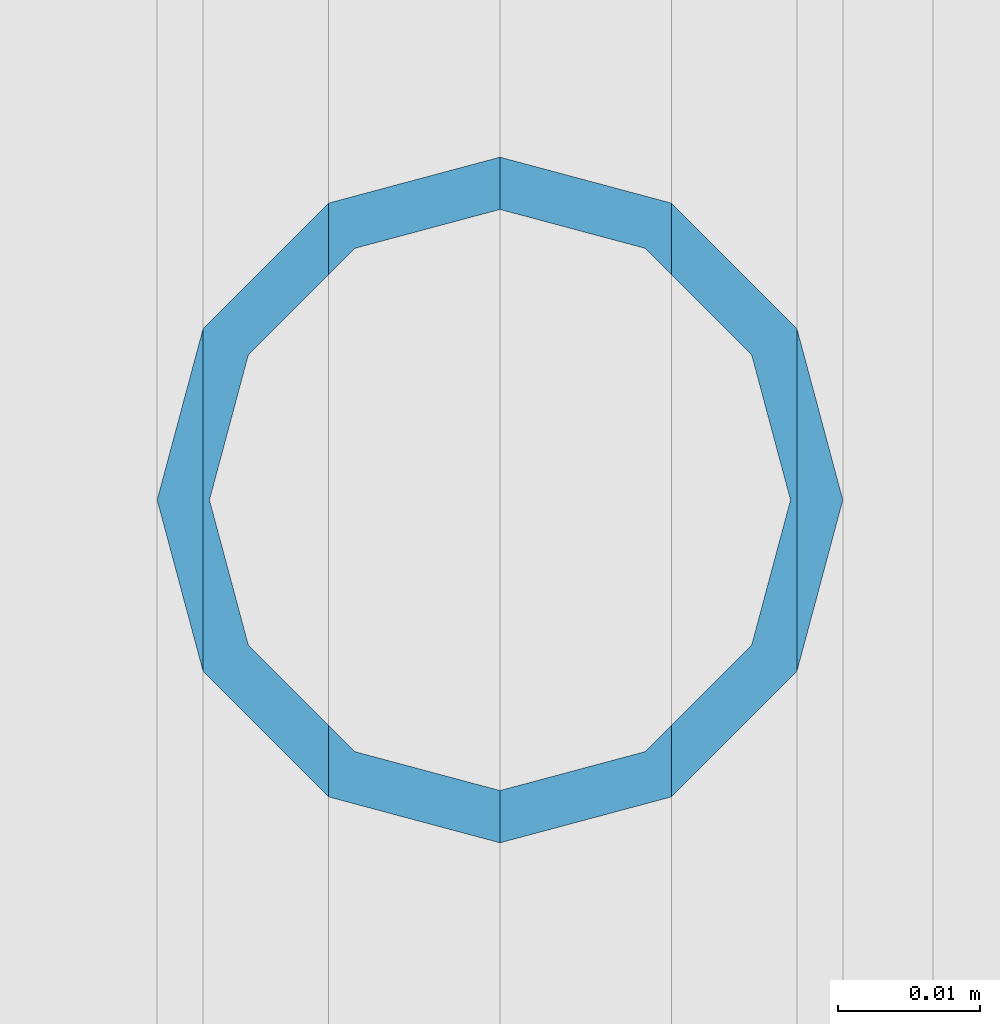
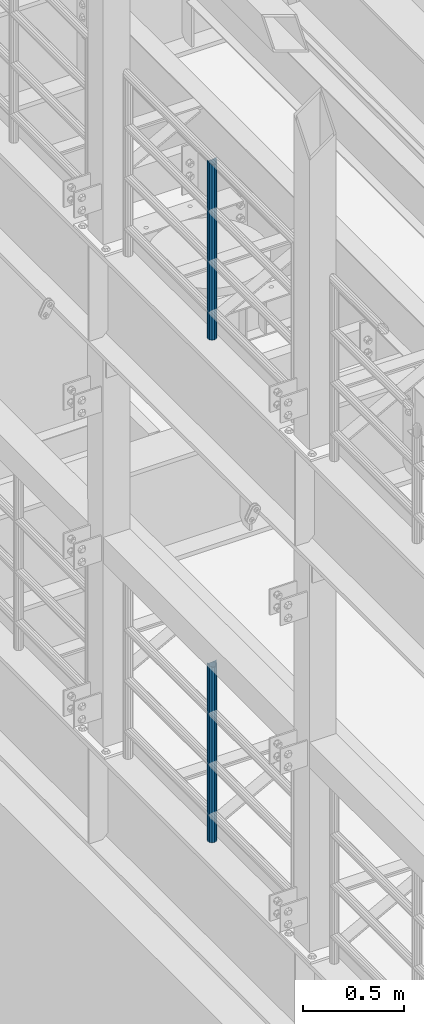
# One storey, part 677 of 1876: 2 columns, 2 elements without a shape of their own.
"""IFC2X3 building model written with IfcOpenShell, lengths in millimetres."""

from ifc_helpers import new_model, si_unit, frame, origin_with_axes, place, context, subcontext, project, spatial, faceted_brep, material, type_object, element, aggregate, save


model = new_model("IFC2X3")

# Units and contexts
model_context = context("Model", 3, precision=1e-05, world=origin_with_axes())
body_context = subcontext(model_context, "Body", "Model", "MODEL_VIEW")
ifc_project = project(units=[si_unit("LENGTHUNIT", "METRE", prefix="MILLI"), si_unit("AREAUNIT", "SQUARE_METRE"), si_unit("VOLUMEUNIT", "CUBIC_METRE"), si_unit("MASSUNIT", "GRAM", prefix="KILO"), si_unit("TIMEUNIT", "SECOND"), si_unit("PLANEANGLEUNIT", "RADIAN"), si_unit("SOLIDANGLEUNIT", "STERADIAN"), si_unit("THERMODYNAMICTEMPERATUREUNIT", "DEGREE_CELSIUS"), si_unit("LUMINOUSINTENSITYUNIT", "LUMEN")], contexts=[model_context])

# Site, building, storey
site_placement = place(None, origin_with_axes())
site = spatial("IfcSite", under=ifc_project, at=site_placement, CompositionType="ELEMENT")
building_placement = place(site_placement, origin_with_axes())
building = spatial("IfcBuilding", under=site, at=building_placement, Name="Undefined", CompositionType="ELEMENT")
storey_placement = place(building_placement, origin_with_axes())
storey = spatial("IfcBuildingStorey", under=building, at=storey_placement, Name="Undefined", CompositionType="ELEMENT", Elevation=0.0)

# Assembly, column
assembly_1_placement = place(storey_placement, origin_with_axes())
assembly_1 = element("IfcElementAssembly", 1, at=assembly_1_placement, inside=storey, Name="RAIL", AssemblyPlace="NOTDEFINED", PredefinedType="RIGID_FRAME")
ifc_material = material()
column_type = type_object("IfcColumnType", Name="PIPE1-1/2SCH40", PredefinedType="NOTDEFINED")
column_1_placement = place(assembly_1_placement, frame((-1.81898940354586e-12, -1524.0, 8153.4), z_axis=(0.0, 1.0, 0.0), x_axis=(0.0, 0.0, 1.0)))
column_1 = element("IfcColumn", 2, at=column_1_placement, type_object=column_type, material=ifc_material, Name="POST", ObjectType="PIPE1-1/2SCH40", context=body_context, shape_type="Brep", body=[
    faceted_brep([(1055.42780700668, -12.0650000000001, 20.8971929933186), (1055.42780700668, -12.0650000000001, 15.8661214311805), (1054.93437856882, -10.2235000000001, 17.7076214311801), (1052.195, 0.0, 20.4470000000001), (1052.195, 0.0, 24.1300000000001), (1054.93437856882, 10.2235000000001, 17.7076214311801), (1055.42780700668, 12.0650000000001, 15.8661214311805), (1055.42780700668, 12.0650000000001, 20.8971929933186), (1076.325, 24.1300000000001, 0.0), (1064.26, 20.8971929933184, 12.0649999999996), (1064.25999999999, 20.8971929933186, -12.0649999999996), (1061.07042843786, 17.7076214311803, 10.2235000000001), (1063.80980700668, 20.4469999999999, 0.0), (1061.07042843786, 17.7076214311803, -10.2235000000001), (1055.42780700668, 12.0650000000001, -15.8661214311805), (1055.42780700667, 12.0649999999996, -20.8971929933186), (1054.93437856882, 10.2235000000001, -17.7076214311801), (1052.195, 0.0, -20.4470000000001), (1052.19499999999, 0.0, -24.1300000000001), (1055.42780700668, -12.0650000000001, -15.8661214311805), (1055.42780700667, -12.0649999999996, -20.8971929933186), (1054.93437856882, -10.2235000000001, -17.7076214311801), (1076.325, -24.1300000000001, 0.0), (1064.25999999999, -20.8971929933186, -12.0649999999996), (1064.26, -20.8971929933184, 12.0649999999996), (1061.07042843786, -17.7076214311803, -10.2235000000001), (1063.80980700668, -20.4469999999999, 0.0), (1061.07042843786, -17.7076214311803, 10.2235000000001), (0.0, -20.8971929933184, -12.0649999999996), (0.0, -12.0650000000001, -20.8971929933186), (-1.45519152283669e-11, 0.0, -24.130000000001), (0.0, 12.0650000000001, -20.8971929933186), (0.0, 20.8971929933184, -12.0649999999996), (0.0, 24.1299999999992, 0.0), (0.0, 20.8971929933184, 12.0649999999996), (0.0, 12.0650000000001, 20.8971929933186), (-1.45519152283669e-11, 0.0, 24.130000000001), (0.0, -12.0650000000001, 20.8971929933186), (0.0, -20.8971929933184, 12.0649999999996), (0.0, -24.1299999999992, 0.0), (0.0, -17.7076214311803, -10.2235000000001), (0.0, -10.2235000000001, -17.7076214311801), (-1.45519152283669e-11, 0.0, -20.4470000000001), (0.0, 10.2235000000001, -17.7076214311801), (0.0, 17.7076214311803, -10.2235000000001), (0.0, 20.4469999999999, 0.0), (0.0, 17.7076214311803, 10.2235000000001), (0.0, 10.2235000000001, 17.7076214311801), (-1.45519152283669e-11, 0.0, 20.4470000000001), (0.0, -10.2235000000001, 17.7076214311801), (0.0, -17.7076214311803, 10.2235000000001), (0.0, -20.4469999999999, 0.0)], [[[0, 1, 2, 3, 4]], [[4, 3, 5, 6, 7]], [[8, 9, 10]], [[7, 6, 11, 12, 13, 14, 15, 10, 9]], [[16, 17, 18, 15, 14]], [[19, 20, 18, 17, 21]], [[22, 23, 24]], [[24, 23, 20, 19, 25, 26, 27, 1, 0]], [[28, 29, 20, 23]], [[29, 30, 18, 20]], [[30, 31, 15, 18]], [[31, 32, 10, 15]], [[32, 33, 8, 10]], [[33, 34, 9, 8]], [[34, 35, 7, 9]], [[35, 36, 4, 7]], [[36, 37, 0, 4]], [[37, 38, 24, 0]], [[38, 39, 22, 24]], [[39, 28, 23, 22]], [[38, 37, 36, 35, 34, 33, 32, 31, 30, 29, 28, 39], [40, 41, 42, 43, 44, 45, 46, 47, 48, 49, 50, 51]], [[40, 51, 26, 25]], [[21, 41, 40, 25, 19]], [[42, 41, 21, 17]], [[43, 42, 17, 16]], [[44, 43, 16, 14, 13]], [[45, 44, 13, 12]], [[46, 45, 12, 11]], [[5, 47, 46, 11, 6]], [[48, 47, 5, 3]], [[49, 48, 3, 2]], [[50, 49, 2, 1, 27]], [[51, 50, 27, 26]]]),
])
aggregate(assembly_1, [column_1])

assembly_2_placement = place(storey_placement, origin_with_axes())
assembly_2 = element("IfcElementAssembly", 3, at=assembly_2_placement, inside=storey, Name="RAIL", AssemblyPlace="NOTDEFINED", PredefinedType="RIGID_FRAME")
column_2_placement = place(assembly_2_placement, frame((-1.81898940354586e-12, -1524.0, 5130.8), z_axis=(0.0, 1.0, 0.0), x_axis=(0.0, 0.0, 1.0)))
column_2 = element("IfcColumn", 4, at=column_2_placement, type_object=column_type, material=ifc_material, Name="POST", ObjectType="PIPE1-1/2SCH40", context=body_context, shape_type="Brep", body=[
    faceted_brep([(1055.42780700668, -12.0650000000001, 20.8971929933186), (1055.42780700668, -12.0650000000001, 15.8661214311805), (1054.93437856882, -10.2235000000001, 17.7076214311801), (1052.195, 0.0, 20.4470000000001), (1052.195, 0.0, 24.1300000000001), (1054.93437856882, 10.2235000000001, 17.7076214311801), (1055.42780700668, 12.0650000000001, 15.8661214311805), (1055.42780700668, 12.0650000000001, 20.8971929933186), (1076.325, 24.1300000000001, 0.0), (1064.26, 20.8971929933184, 12.0649999999996), (1064.25999999999, 20.8971929933186, -12.0649999999996), (1061.07042843786, 17.7076214311803, 10.2235000000001), (1063.80980700668, 20.4469999999999, 0.0), (1061.07042843786, 17.7076214311803, -10.2235000000001), (1055.42780700668, 12.0650000000001, -15.8661214311805), (1055.42780700667, 12.0649999999996, -20.8971929933186), (1054.93437856882, 10.2235000000001, -17.7076214311801), (1052.195, 0.0, -20.4470000000001), (1052.19499999999, 0.0, -24.1300000000001), (1055.42780700668, -12.0650000000001, -15.8661214311805), (1055.42780700667, -12.0649999999996, -20.8971929933186), (1054.93437856882, -10.2235000000001, -17.7076214311801), (1076.325, -24.1300000000001, 0.0), (1064.25999999999, -20.8971929933186, -12.0649999999996), (1064.26, -20.8971929933184, 12.0649999999996), (1061.07042843786, -17.7076214311803, -10.2235000000001), (1063.80980700668, -20.4469999999999, 0.0), (1061.07042843786, -17.7076214311803, 10.2235000000001), (0.0, -20.8971929933184, -12.0649999999996), (0.0, -12.0650000000001, -20.8971929933186), (-1.45519152283669e-11, 0.0, -24.130000000001), (0.0, 12.0650000000001, -20.8971929933186), (0.0, 20.8971929933184, -12.0649999999996), (0.0, 24.1299999999992, 0.0), (0.0, 20.8971929933184, 12.0649999999996), (0.0, 12.0650000000001, 20.8971929933186), (-1.45519152283669e-11, 0.0, 24.130000000001), (0.0, -12.0650000000001, 20.8971929933186), (0.0, -20.8971929933184, 12.0649999999996), (0.0, -24.1299999999992, 0.0), (0.0, -17.7076214311803, -10.2235000000001), (0.0, -10.2235000000001, -17.7076214311801), (-1.45519152283669e-11, 0.0, -20.4470000000001), (0.0, 10.2235000000001, -17.7076214311801), (0.0, 17.7076214311803, -10.2235000000001), (0.0, 20.4469999999999, 0.0), (0.0, 17.7076214311803, 10.2235000000001), (0.0, 10.2235000000001, 17.7076214311801), (-1.45519152283669e-11, 0.0, 20.4470000000001), (0.0, -10.2235000000001, 17.7076214311801), (0.0, -17.7076214311803, 10.2235000000001), (0.0, -20.4469999999999, 0.0)], [[[0, 1, 2, 3, 4]], [[4, 3, 5, 6, 7]], [[8, 9, 10]], [[7, 6, 11, 12, 13, 14, 15, 10, 9]], [[16, 17, 18, 15, 14]], [[19, 20, 18, 17, 21]], [[22, 23, 24]], [[24, 23, 20, 19, 25, 26, 27, 1, 0]], [[28, 29, 20, 23]], [[29, 30, 18, 20]], [[30, 31, 15, 18]], [[31, 32, 10, 15]], [[32, 33, 8, 10]], [[33, 34, 9, 8]], [[34, 35, 7, 9]], [[35, 36, 4, 7]], [[36, 37, 0, 4]], [[37, 38, 24, 0]], [[38, 39, 22, 24]], [[39, 28, 23, 22]], [[38, 37, 36, 35, 34, 33, 32, 31, 30, 29, 28, 39], [40, 41, 42, 43, 44, 45, 46, 47, 48, 49, 50, 51]], [[40, 51, 26, 25]], [[21, 41, 40, 25, 19]], [[42, 41, 21, 17]], [[43, 42, 17, 16]], [[44, 43, 16, 14, 13]], [[45, 44, 13, 12]], [[46, 45, 12, 11]], [[5, 47, 46, 11, 6]], [[48, 47, 5, 3]], [[49, 48, 3, 2]], [[50, 49, 2, 1, 27]], [[51, 50, 27, 26]]]),
])
aggregate(assembly_2, [column_2])

save(model, "model.ifc")
